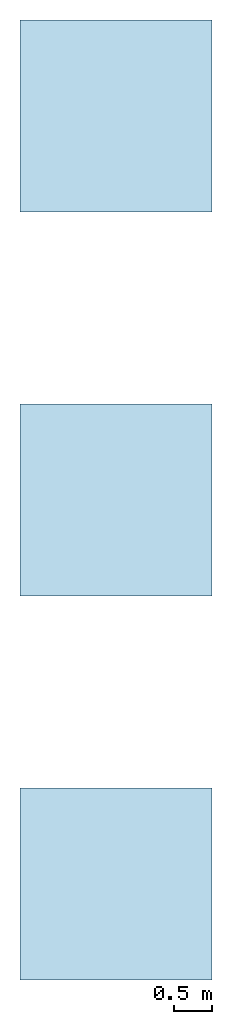
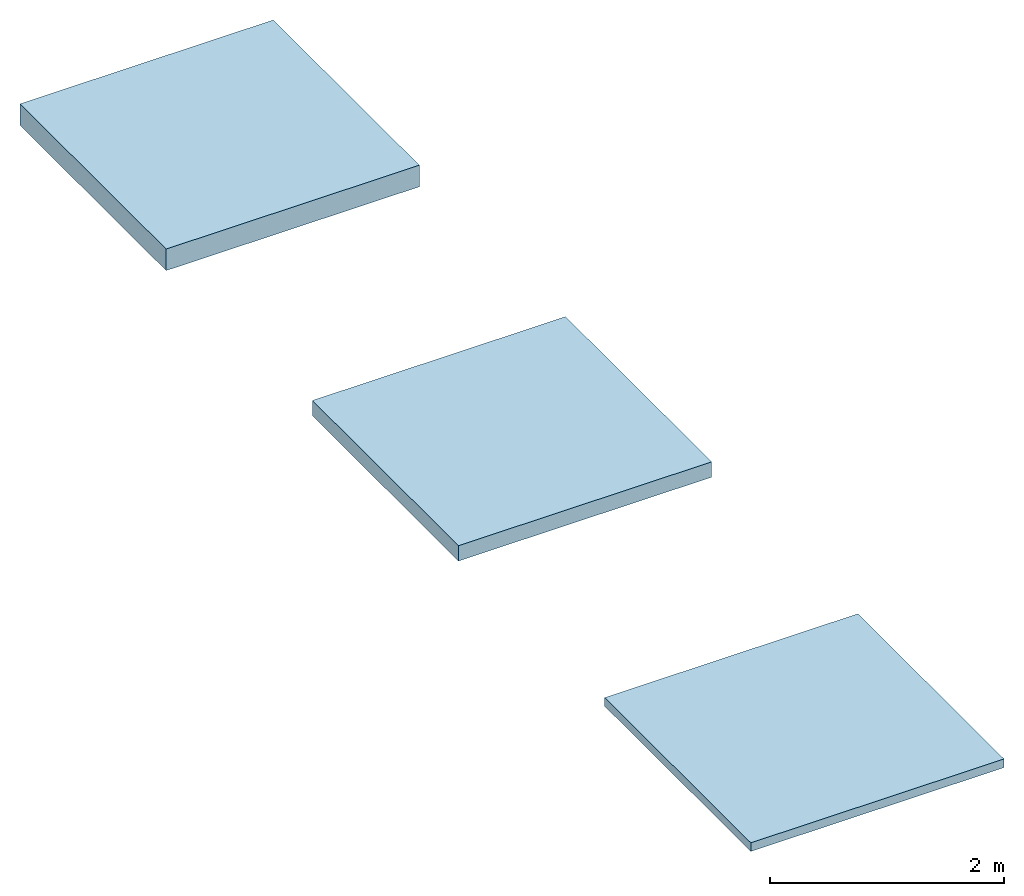
# Not in any storey: 3 slabs.
"""IFC2X3 building model written with IfcOpenShell, lengths in millimetres."""

from ifc_helpers import new_model, si_unit, frame, frame_2d, origin, origin_with_axes, origin_2d, place, context, project, spatial, rectangle, extrude, material, layer, layer_set, layer_usage, type_object, element, save


model = new_model("IFC2X3")

# Units and contexts
model_context = context("Model", 3, precision=1e-05, world=origin())
plan_context = context("Plan", 2, precision=1e-05, world=origin_2d())
ifc_project = project(units=[si_unit("LENGTHUNIT", "METRE", prefix="MILLI"), si_unit("AREAUNIT", "SQUARE_METRE"), si_unit("VOLUMEUNIT", "CUBIC_METRE"), si_unit("SOLIDANGLEUNIT", "STERADIAN"), si_unit("PLANEANGLEUNIT", "RADIAN"), si_unit("MASSUNIT", "GRAM"), si_unit("TIMEUNIT", "SECOND"), si_unit("THERMODYNAMICTEMPERATUREUNIT", "DEGREE_CELSIUS"), si_unit("LUMINOUSINTENSITYUNIT", "LUMEN")], contexts=[model_context, plan_context])

# Site, building
site_placement = place(None, frame((0.0, 0.0, 0.0), z_axis=(0.0, 1.0, 0.0), x_axis=(0.0, 0.0, 1.0)))
site = spatial("IfcSite", under=ifc_project, at=site_placement, CompositionType="ELEMENT")
building_placement = place(site_placement, frame((0.0, 0.0, 0.0), z_axis=(0.0, 1.0, 0.0), x_axis=(0.0, 0.0, 1.0)))
building = spatial("IfcBuilding", under=site, at=building_placement, Name="Default building", CompositionType="ELEMENT")

# Slabs
ifc_material_1 = material()
ifc_layer_1 = layer(ifc_material_1, 90.0, ventilated=False)
ifc_layer_set_1 = layer_set([ifc_layer_1])
ifc_layer_usage_1 = layer_usage(ifc_layer_set_1, "AXIS3", "NEGATIVE", 0.0)
slab_type_1 = type_object("IfcSlabType", PredefinedType="FLOOR", material=ifc_layer_set_1)
slab_1_placement = place(None, origin())
element("IfcSlab", 1, at=slab_1_placement, inside=building, type_object=slab_type_1, material=ifc_layer_usage_1, PredefinedType="FLOOR", context=model_context, shape_type="SweptSolid", body=[
    extrude(rectangle(XDim=2500.0, YDim=2500.0, at=frame_2d((1250.0, 1250.0))), origin_with_axes(), (0.0, 0.0, 1.0), 90.0),
])
ifc_material_2 = material()
ifc_layer_2 = layer(ifc_material_2, 160.0, ventilated=False)
ifc_layer_set_2 = layer_set([ifc_layer_2])
ifc_layer_usage_2 = layer_usage(ifc_layer_set_2, "AXIS3", "NEGATIVE", 0.0)
slab_type_2 = type_object("IfcSlabType", PredefinedType="FLOOR", material=ifc_layer_set_2)
slab_2_placement = place(None, frame((0.0, 5000.0, 0.0)))
element("IfcSlab", 2, at=slab_2_placement, inside=building, type_object=slab_type_2, material=ifc_layer_usage_2, PredefinedType="FLOOR", context=model_context, shape_type="SweptSolid", body=[
    extrude(rectangle(XDim=2500.0, YDim=2500.0, at=frame_2d((1250.0, 1250.0))), origin_with_axes(), (0.0, 0.0, 1.0), 160.0),
])
ifc_material_3 = material()
ifc_layer_3 = layer(ifc_material_3, 225.0, ventilated=False)
ifc_layer_set_3 = layer_set([ifc_layer_3])
ifc_layer_usage_3 = layer_usage(ifc_layer_set_3, "AXIS3", "NEGATIVE", 0.0)
slab_type_3 = type_object("IfcSlabType", PredefinedType="FLOOR", material=ifc_layer_set_3)
slab_3_placement = place(None, frame((0.0, 10000.0, 0.0)))
element("IfcSlab", 3, at=slab_3_placement, inside=building, type_object=slab_type_3, material=ifc_layer_usage_3, PredefinedType="FLOOR", context=model_context, shape_type="SweptSolid", body=[
    extrude(rectangle(XDim=2500.0, YDim=2500.0, at=frame_2d((1250.0, 1250.0))), origin_with_axes(), (0.0, 0.0, 1.0), 225.0),
])

save(model, "model.ifc")
